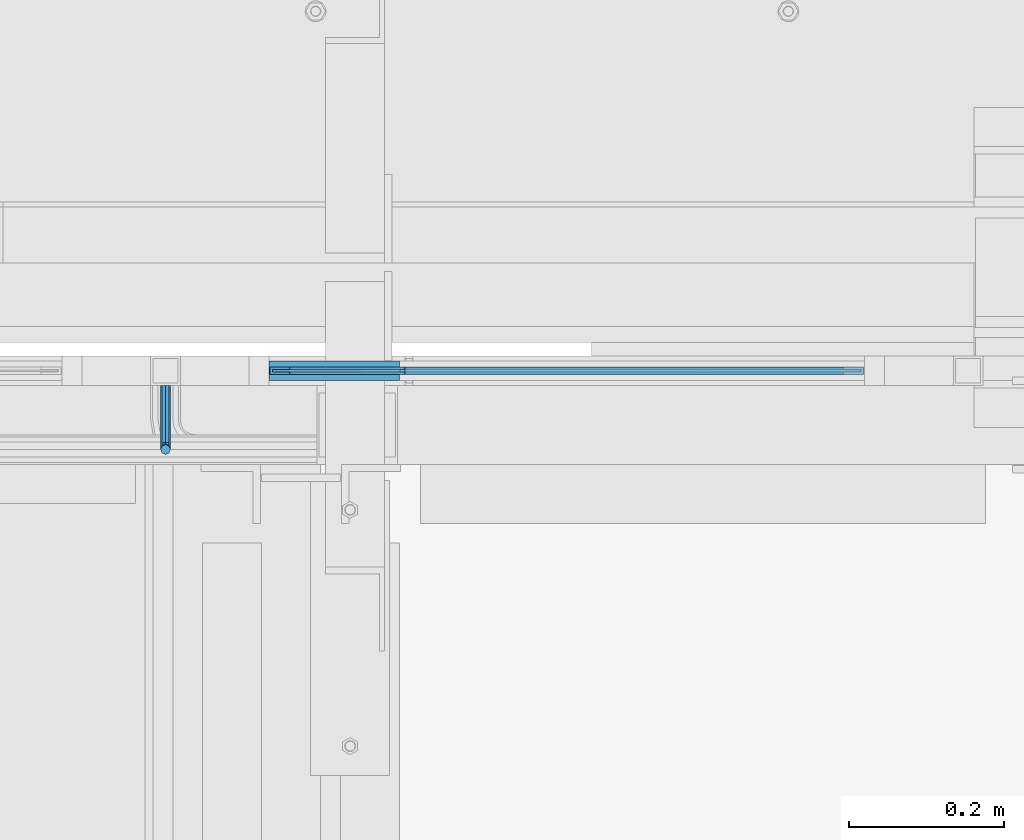
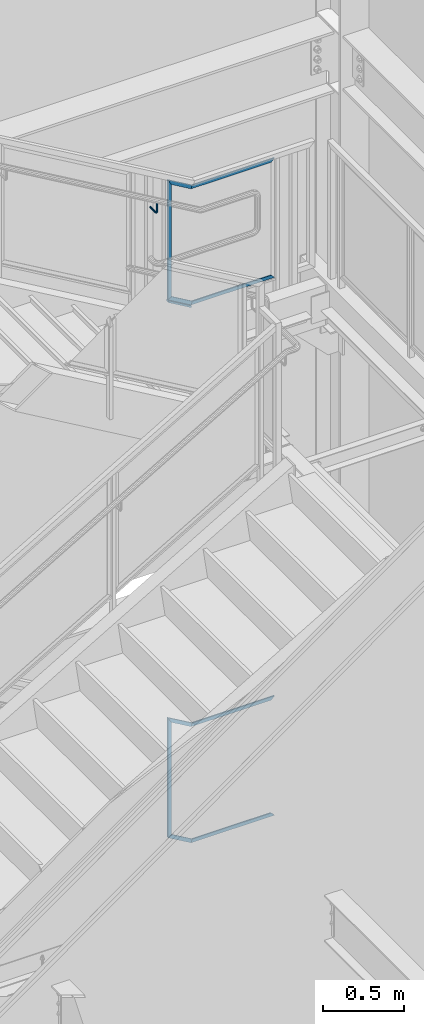
# One storey, part 950 of 1179: 11 beams, 1 member, 2 elements without a shape of their own.
"""IFC2X3 building model written with IfcOpenShell, lengths in millimetres."""

from ifc_helpers import new_model, si_unit, frame, origin_with_axes, place, context, subcontext, project, spatial, faceted_brep, material, type_object, element, aggregate, save


model = new_model("IFC2X3")

# Units and contexts
model_context = context("Model", 3, precision=1e-05, world=origin_with_axes())
body_context = subcontext(model_context, "Body", "Model", "MODEL_VIEW")
ifc_project = project(units=[si_unit("LENGTHUNIT", "METRE", prefix="MILLI"), si_unit("AREAUNIT", "SQUARE_METRE"), si_unit("VOLUMEUNIT", "CUBIC_METRE"), si_unit("MASSUNIT", "GRAM", prefix="KILO"), si_unit("TIMEUNIT", "SECOND"), si_unit("PLANEANGLEUNIT", "RADIAN"), si_unit("SOLIDANGLEUNIT", "STERADIAN"), si_unit("THERMODYNAMICTEMPERATUREUNIT", "DEGREE_CELSIUS"), si_unit("LUMINOUSINTENSITYUNIT", "LUMEN")], contexts=[model_context])

# Site, building, storey
site_placement = place(None, origin_with_axes())
site = spatial("IfcSite", under=ifc_project, at=site_placement, CompositionType="ELEMENT")
building_placement = place(site_placement, origin_with_axes())
building = spatial("IfcBuilding", under=site, at=building_placement, Name="Undefined", CompositionType="ELEMENT")
storey_placement = place(building_placement, origin_with_axes())
storey = spatial("IfcBuildingStorey", under=building, at=storey_placement, Name="Undefined", CompositionType="ELEMENT", Elevation=0.0)

# Assembly, beams
assembly_1_placement = place(storey_placement, origin_with_axes())
assembly_1 = element("IfcElementAssembly", 1, at=assembly_1_placement, inside=storey, Name="GUARDRAIL", AssemblyPlace="NOTDEFINED", PredefinedType="RIGID_FRAME")
ifc_material_1 = material(Name="STEEL/BUY-OUT")
beam_type_1 = type_object("IfcBeamType", PredefinedType="NOTDEFINED")
beam_1_placement = place(assembly_1_placement, frame((23004.4625009229, 41062.2751647691, 7024.57509134663), z_axis=(0.0, 0.0, -1.0), x_axis=(-1.0, 0.0, 0.0)))
beam_1 = element("IfcBeam", 2, at=beam_1_placement, type_object=beam_type_1, material=ifc_material_1, Name="U-EDGE", context=body_context, shape_type="Brep", body=[
    faceted_brep([(0.0, 1.58750000000146, -270.003166662049), (0.0, -1.58750000000146, -270.003166662049), (0.0, -1.58750000000146, 579.92999369853), (0.0, 1.58750000000146, 579.92999369853), (22.225000034312, 1.58750000000146, -308.697692489856), (22.225000034312, 1.58750000000146, 592.695374273017), (22.225000034312, 4.76249999999709, -308.697692489856), (22.225000034312, 4.76249999999709, 592.695374273017), (6.88160071149468e-08, 4.76249999999709, -270.00316678186), (6.88160071149468e-08, 4.76249999999709, 579.929993738056), (6.88160071149468e-08, 7.9375, -270.00316678186), (6.88160071149468e-08, 7.9375, 579.929993738056), (25.4000000343149, 7.9375, -314.225481885294), (25.4000000343149, 7.9375, 594.519), (25.4000000343149, -1.58750000000146, -314.225481885294), (25.4000000343149, -1.58750000000146, 594.519)], [[[0, 1, 2, 3]], [[4, 0, 3, 5]], [[6, 4, 5, 7]], [[8, 6, 7, 9]], [[10, 8, 9, 11]], [[12, 10, 11, 13]], [[14, 12, 13, 15]], [[11, 9, 7, 5, 3, 2, 15, 13]], [[1, 14, 15, 2]], [[0, 4, 6, 8, 10, 12, 14, 1]]]),
])
beam_2_placement = place(assembly_1_placement, frame((23479.7973020287, 41062.2751647691, 7017.29993523606), z_axis=(0.863778851027978, 0.0, -0.503871111016285), x_axis=(0.503871025088838, 0.0, 0.863778901152328)))
beam_2 = element("IfcBeam", 3, at=beam_2_placement, type_object=beam_type_1, material=ifc_material_1, Name="U-EDGE", context=body_context, shape_type="Brep", body=[
    faceted_brep([(-2.06637196242809e-09, 1.58750000000146, -386.433666311852), (25.4000002048124, 1.58750000000146, -393.300527584164), (25.4000001784334, 1.58750000000146, -594.51900000087), (-2.9431248549372e-09, 1.58750000000146, -550.296685272686), (-2.06637196242809e-09, -1.58750000000146, -386.433666311852), (-2.9431248549372e-09, -1.58750000000146, -550.296685272686), (22.2250002049223, -1.58750000000146, -392.44216993215), (22.2250001791581, -1.58750000000146, -588.991210579159), (22.2250002542896, -4.76249993750389, -392.442169945494), (22.2250002532455, -4.76249990620272, -588.991210708155), (5.21009496878833e-07, -4.76249995140824, -386.433666453266), (5.25629729963839e-07, -4.76249993080273, -550.296686192945), (5.21009496878833e-07, -7.93749995141116, -386.433666453266), (5.25629729963839e-07, -7.93749993080564, -550.296686192945), (25.4000002542853, -7.93749993736856, -393.300527597541), (25.4000002532193, -7.93749990531796, -594.51900000187)], [[[0, 1, 2, 3]], [[4, 0, 3, 5]], [[6, 4, 5, 7]], [[8, 6, 7, 9]], [[10, 8, 9, 11]], [[12, 10, 11, 13]], [[14, 12, 13, 15]], [[11, 9, 7, 5, 3, 2, 15, 13]], [[1, 14, 15, 2]], [[0, 4, 6, 8, 10, 12, 14, 1]]]),
])
beam_3_placement = place(assembly_1_placement, frame((22645.5025845213, 41062.2751647691, 6654.0383825364), z_axis=(0.863778851027978, 0.0, -0.503871111016285), x_axis=(-0.503871111016286, 0.0, -0.863778851027978)))
beam_3 = element("IfcBeam", 4, at=beam_3_placement, type_object=beam_type_1, material=ifc_material_1, Name="U-EDGE", context=body_context, shape_type="Brep", body=[
    faceted_brep([(-2.69210431724787e-09, 1.58750000000146, 415.569211323445), (-2.69210431724787e-09, -1.58750000000146, 415.569211323445), (-3.80168785341084e-09, -1.58750000000146, 587.652134403934), (-3.80168785341084e-09, 1.58750000000146, 587.652134403934), (22.2250000252243, 1.58750000000146, 402.803830595183), (22.225000019891, 1.58750000000146, 593.660643821861), (22.2250000338972, 4.76249998905405, 402.803830590206), (22.2250000326712, 4.76249998386629, 593.660643825317), (7.23375706002116e-08, 4.76249999106949, 415.569211280346), (7.22138793207705e-08, 4.7624999873733, 587.652134424485), (7.23375706002116e-08, 7.9374999910724, 415.56921128035), (7.22138793207705e-08, 7.93749998736894, 587.652134424485), (25.4000000339074, 7.93749998910062, 400.980204774167), (25.4000000343149, 7.9375, 594.519), (25.4000000252745, -1.58750000000146, 400.980204779122), (25.4000000343149, -1.58750000000146, 594.519)], [[[0, 1, 2, 3]], [[4, 0, 3, 5]], [[6, 4, 5, 7]], [[8, 6, 7, 9]], [[10, 8, 9, 11]], [[12, 10, 11, 13]], [[14, 12, 13, 15]], [[11, 9, 7, 5, 3, 2, 15, 13]], [[1, 14, 15, 2]], [[0, 4, 6, 8, 10, 12, 14, 1]]]),
])
beam_4_placement = place(assembly_1_placement, frame((23149.7190009069, 41062.2751647691, 6357.93700004089), z_axis=(1.0, 0.0, 0.0), x_axis=(0.0, 0.0, -1.0)))
beam_4 = element("IfcBeam", 5, at=beam_4_placement, type_object=beam_type_1, material=ifc_material_1, Name="U-EDGE", context=body_context, shape_type="Brep", body=[
    faceted_brep([(0.0, 1.58750000000146, 3.38468742659097), (0.0, -1.58750000000146, 3.38468742659097), (0.0, -1.58750000000146, 569.118999689985), (0.0, 1.58750000000146, 569.118999689985), (22.2250000408876, 1.58750000000146, -2.62382239321596), (22.2250000408876, 1.58750000000146, 591.343999668014), (22.2250000408876, 4.76249999999709, -2.62382239321596), (22.2250000408876, 4.76249999999709, 591.343999668014), (8.17417458165437e-08, 4.76249999999709, 3.38468740449025), (8.17417458165437e-08, 4.76249999999709, 569.118999771727), (8.17417458165437e-08, 7.9375, 3.38468740449025), (8.17417458165437e-08, 7.9375, 569.118999771727), (25.4000000408869, 7.9375, -3.4821809373243), (25.4000000343149, 7.9375, 594.519), (25.4000000408869, -1.58750000000146, -3.4821809373243), (25.4000000343149, -1.58750000000146, 594.519)], [[[0, 1, 2, 3]], [[4, 0, 3, 5]], [[6, 4, 5, 7]], [[8, 6, 7, 9]], [[10, 8, 9, 11]], [[12, 10, 11, 13]], [[14, 12, 13, 15]], [[11, 9, 7, 5, 3, 2, 15, 13]], [[1, 14, 15, 2]], [[0, 4, 6, 8, 10, 12, 14, 1]]]),
])
beam_5_placement = place(assembly_1_placement, frame((23149.7190009037, 41062.2751647691, 7212.01200005103), z_axis=(1.0, 0.0, 0.0), x_axis=(0.0, 0.0, 1.0)))
beam_5 = element("IfcBeam", 6, at=beam_5_placement, type_object=beam_type_1, material=ifc_material_1, Name="U-EDGE", context=body_context, shape_type="Brep", body=[
    faceted_brep([(-1.02174453786574e-07, -4.76249999999709, -3.71549147667611), (-1.02174453786574e-07, -7.9375, -3.71549147667611), (-1.02174453786574e-07, -7.9375, 569.11899985779), (-1.02174453786574e-07, -4.76249999999709, 569.11899985779), (22.2249999489695, -4.76249999999709, 2.29301266474431), (22.2249999489695, -4.76249999999709, 591.343999971796), (22.2249999489695, -1.58750000000146, 2.29301266474431), (22.2249999489695, -1.58750000000146, 591.343999971796), (0.0, -1.58750000000146, -3.71549144905293), (0.0, -1.58750000000146, 569.118999689985), (0.0, 1.58750000000146, -3.71549144905293), (0.0, 1.58750000000146, 569.118999689985), (25.3999999489688, 1.58750000000146, 3.15137039725596), (25.3999999489688, 1.58750000000146, 594.519), (25.3999999489688, -7.9375, 3.15137039725596), (25.3999999489688, -7.9375, 594.519)], [[[0, 1, 2, 3]], [[4, 0, 3, 5]], [[6, 4, 5, 7]], [[8, 6, 7, 9]], [[10, 8, 9, 11]], [[12, 10, 11, 13]], [[14, 12, 13, 15]], [[11, 9, 7, 5, 3, 2, 15, 13]], [[1, 14, 15, 2]], [[0, 4, 6, 8, 10, 12, 14, 1]]]),
])

assembly_2_placement = place(storey_placement, origin_with_axes())
assembly_2 = element("IfcElementAssembly", 7, at=assembly_2_placement, inside=storey, Name="GUARDRAIL", AssemblyPlace="NOTDEFINED", PredefinedType="RIGID_FRAME")
beam_6_placement = place(assembly_2_placement, frame((23004.2487243082, 41062.2751647691, 2812.82353977758), z_axis=(0.0, 0.0, -1.0), x_axis=(-1.0, 0.0, 0.0)))
beam_6 = element("IfcBeam", 8, at=beam_6_placement, type_object=beam_type_1, material=ifc_material_1, Name="U-EDGE", context=body_context, shape_type="Brep", body=[
    faceted_brep([(2.91038304567337e-11, 7.9375, 442.556144312037), (25.400000000016, 7.9375, 457.2), (25.400000000016, 7.9375, -451.842250711938), (2.91038304567337e-11, 7.9375, -407.785547856803), (2.91038304567337e-11, 4.76249999999709, 442.556144312037), (2.91038304567337e-11, 4.76249999999709, -407.785547856803), (22.2250000000131, 4.76249999999709, 455.369518039193), (22.2250000000131, 4.76249999999709, -446.335162855043), (22.2250000000131, 1.58750000000146, 455.369518039193), (22.2250000000131, 1.58750000000146, -446.335162855043), (0.0, 1.58750000000146, 442.55614431202), (0.0, 1.58750000000146, -407.785547856753), (0.0, -1.58750000000146, 442.55614431202), (0.0, -1.58750000000146, -407.785547856753), (25.400000000016, -1.58750000000146, 457.2), (25.400000000016, -1.58750000000146, -451.842250711938)], [[[0, 1, 2, 3]], [[4, 0, 3, 5]], [[6, 4, 5, 7]], [[8, 6, 7, 9]], [[10, 8, 9, 11]], [[12, 10, 11, 13]], [[14, 12, 13, 15]], [[11, 9, 7, 5, 3, 2, 15, 13]], [[1, 14, 15, 2]], [[0, 4, 6, 8, 10, 12, 14, 1]]]),
])
beam_7_placement = place(assembly_2_placement, frame((23357.6651990045, 41062.2751647691, 3015.98340288031), z_axis=(0.86540914081268, 0.0, -0.501065882891521), x_axis=(0.501065882891522, 0.0, 0.865409140812679)))
beam_7 = element("IfcBeam", 9, at=beam_7_placement, type_object=beam_type_1, material=ifc_material_1, Name="U-EDGE", context=body_context, shape_type="Brep", body=[
    faceted_brep([(9.74741851678118e-08, -4.76249999670108, -408.380797089678), (9.74741851678118e-08, -7.93749999670399, -408.380797089678), (9.7581505542621e-08, -7.93749999802822, -244.487005042745), (9.7581505542621e-08, -4.76249999802531, -244.487005042745), (22.225000047627, -4.76249999544962, -446.930412123944), (22.2250000481799, -4.7624999974505, -250.45684240964), (22.2250000440508, -1.58750000000146, -446.930412117745), (22.2250000461772, -1.58750000000146, -250.456842409101), (-1.1423253454268e-09, -1.58750000000146, -408.380796918627), (-6.82121026329696e-10, -1.58750000000146, -244.487005016344), (-1.1423253454268e-09, 1.58750000000146, -408.380796918627), (-6.82121026329696e-10, 1.58750000000146, -244.487005016344), (25.4000000439901, 1.58750000000146, -452.437500000357), (25.4000000461656, 1.58750000000146, -251.309676320547), (25.4000000476099, -7.93749999539432, -452.437500000422), (25.4000000481774, -7.93749999743886, -251.309676321089)], [[[0, 1, 2, 3]], [[4, 0, 3, 5]], [[6, 4, 5, 7]], [[8, 6, 7, 9]], [[10, 8, 9, 11]], [[12, 10, 11, 13]], [[14, 12, 13, 15]], [[11, 9, 7, 5, 3, 2, 15, 13]], [[1, 14, 15, 2]], [[0, 4, 6, 8, 10, 12, 14, 1]]]),
])
beam_8_placement = place(assembly_2_placement, frame((23291.8000029085, 41062.2751647691, 3138.48749992319), z_axis=(1.0, 0.0, 0.0), x_axis=(0.0, 0.0, 1.0)))
beam_8 = element("IfcBeam", 10, at=beam_8_placement, type_object=beam_type_1, material=ifc_material_1, Name="U-EDGE", context=body_context, shape_type="Brep", body=[
    faceted_brep([(1.29148247651756e-10, -4.76249999999709, -145.716092850209), (22.2250000000645, -4.76249999999709, -139.746255438797), (22.2250000000645, -1.58750000000146, -139.746255438797), (0.0, -1.58750000000146, -145.716092850242), (0.0, 1.58750000000146, -145.716092850242), (25.4000000000647, 1.58750000000146, -138.893421522876), (25.4000000000647, -7.9375, -138.893421522876), (1.29148247651756e-10, -7.9375, -145.716092850209), (25.4000000000647, -7.9375, 452.4375), (1.29148247651756e-10, -7.9375, 427.037500076181), (1.29148247651756e-10, -4.76249999999709, 427.037500076181), (22.2250000000645, -4.76249999999709, 449.262500076118), (22.2250000000645, -1.58750000000146, 449.262500076118), (0.0, -1.58750000000146, 427.037500076054), (0.0, 1.58750000000146, 427.037500076054), (25.4000000000647, 1.58750000000146, 452.4375)], [[[0, 1, 2, 3, 4, 5, 6, 7]], [[7, 6, 8, 9]], [[0, 7, 9, 10]], [[1, 0, 10, 11]], [[2, 1, 11, 12]], [[3, 2, 12, 13]], [[4, 3, 13, 14]], [[5, 4, 14, 15]], [[6, 5, 15, 8]], [[14, 13, 12, 11, 10, 9, 8, 15]]]),
])
beam_9_placement = place(assembly_2_placement, frame((22643.9340672807, 41062.2751647691, 2578.88707990434), z_axis=(0.86540914081268, 0.0, -0.501065882891521), x_axis=(-0.501065882891527, 0.0, -0.865409140812677)))
beam_9 = element("IfcBeam", 11, at=beam_9_placement, type_object=beam_type_1, material=ifc_material_1, Name="U-EDGE", context=body_context, shape_type="Brep", body=[
    faceted_brep([(2.39240762311965e-07, 7.93749999378633, 587.696328464168), (25.4000000343149, 7.9375, 594.519), (25.4000001184813, 7.93749999461579, 401.707948420833), (2.39342625718564e-07, 7.93749999559805, 416.351804051519), (2.39240762311965e-07, 4.76249999378342, 587.696328464168), (2.39342625718564e-07, 4.76249999559514, 416.351804051519), (22.2250001178327, 4.76249999204447, 593.666165840914), (22.2250001184766, 4.76249999459105, 403.538430383382), (22.2250001115262, 1.58750000000146, 593.666165839222), (22.2250001141911, 1.58750000000146, 403.538430385848), (-2.01180228032172e-09, 1.58750000000146, 587.696328399368), (-1.42608769237995e-09, 1.58750000000146, 416.351804190326), (-2.01180228032172e-09, -1.58750000000146, 587.696328399368), (-1.42608769237995e-09, -1.58750000000146, 416.351804190326), (25.4000000343149, -1.58750000000146, 594.519), (25.4000001142158, -1.58750000000146, 401.707948423293)], [[[0, 1, 2, 3]], [[4, 0, 3, 5]], [[6, 4, 5, 7]], [[8, 6, 7, 9]], [[10, 8, 9, 11]], [[12, 10, 11, 13]], [[14, 12, 13, 15]], [[11, 9, 7, 5, 3, 2, 15, 13]], [[1, 14, 15, 2]], [[0, 4, 6, 8, 10, 12, 14, 1]]]),
])
beam_10_placement = place(assembly_2_placement, frame((23149.7185024644, 41062.2751647691, 2284.41250011933), z_axis=(1.0, 0.0, 0.0), x_axis=(0.0, 0.0, -1.0)))
beam_10 = element("IfcBeam", 12, at=beam_10_placement, type_object=beam_type_1, material=ifc_material_1, Name="U-EDGE", context=body_context, shape_type="Brep", body=[
    faceted_brep([(8.17417458165437e-08, 7.9375, 569.118999771727), (25.4000000343149, 7.9375, 594.519), (25.4000001193604, 7.9375, -4.00933168713891), (2.38696884480305e-07, 7.9375, 2.81333957478637), (8.17417458165437e-08, 4.76249999999709, 569.118999771727), (2.38696884480305e-07, 4.76249999999709, 2.81333957478637), (22.2250000408876, 4.76249999999709, 591.343999668014), (22.2250001193602, 4.76249999999709, -3.15649777539147), (22.2250000408876, 1.58750000000146, 591.343999668014), (22.2250001193602, 1.58750000000146, -3.15649777539147), (0.0, 1.58750000000146, 569.118999689985), (0.0, 1.58750000000146, 2.81333963890211), (0.0, -1.58750000000146, 569.118999689985), (0.0, -1.58750000000146, 2.81333963890211), (25.4000000343149, -1.58750000000146, 594.519), (25.4000001193604, -1.58750000000146, -4.00933168713891)], [[[0, 1, 2, 3]], [[4, 0, 3, 5]], [[6, 4, 5, 7]], [[8, 6, 7, 9]], [[10, 8, 9, 11]], [[12, 10, 11, 13]], [[14, 12, 13, 15]], [[11, 9, 7, 5, 3, 2, 15, 13]], [[1, 14, 15, 2]], [[0, 4, 6, 8, 10, 12, 14, 1]]]),
])
aggregate(assembly_2, [beam_6, beam_7, beam_8, beam_9, beam_10])

# Beam
ifc_material_2 = material(Name="STEEL/A36")
beam_type_2 = type_object("IfcBeamType", PredefinedType="NOTDEFINED")
beam_11_placement = place(assembly_1_placement, frame((22844.1250009055, 41046.3999992326, 7190.79354012369), z_axis=(0.0, 0.0, 1.0), x_axis=(0.0, -1.0, 0.0)))
beam_11 = element("IfcBeam", 13, at=beam_11_placement, type_object=beam_type_2, material=ifc_material_2, Name="BRACKET", context=body_context, shape_type="Brep", body=[
    faceted_brep([(0.0, -4.49012806053361, 4.49012806053452), (0.0, 0.0, 6.34999999999991), (0.0, 4.49012806053361, 4.49012806053452), (0.0, 6.34999999999854, 0.0), (0.0, 4.49012806053361, -4.49012806053452), (0.0, 0.0, -6.34999999999991), (0.0, -4.49012806053361, -4.49012806053452), (0.0, -6.34999999999854, 0.0), (69.849999425729, 0.0, -6.34999999999991), (69.849999425729, -4.49012806053361, -4.49012806053452), (69.849999425729, -6.34999999999854, 0.0), (69.849999425729, -4.49012806053361, 4.49012806053452), (69.849999425729, 0.0, 6.34999999999991), (69.849999425729, 4.49012806053361, 4.49012806053452), (69.849999425729, 6.34999999999854, 0.0), (69.849999425729, 4.49012806053361, -4.49012806053452), (78.445063360632, 4.49012806053361, -2.18708762028064), (79.3749993303718, 0.0, -3.79778396764323), (78.445063360632, -4.49012806053361, -2.18708762028064), (76.1999993303689, -6.34999999999854, 1.70147734638658), (73.9549353000984, -4.49012806053361, 5.59004231305425), (73.024999330366, 0.0, 7.20073866041639), (73.9549353000984, 4.49012806053361, 5.59004231305425), (76.1999993303689, 6.34999999999854, 1.70147734638658), (80.8485218886053, 6.34999999999854, 6.34999990462893), (84.7370868552753, 4.49012806053361, 4.10493587436031), (76.9599569219426, 4.49012806053361, 8.59506393489755), (75.3492605745778, 0.0, 9.52499990463093), (76.9599569219426, -4.49012806053361, 8.59506393489755), (80.8485218886053, -6.34999999999854, 6.34999990462893), (84.7370868552753, -4.49012806053361, 4.10493587436031), (86.3477832026401, 0.0, 3.17499990462693), (87.0401272955278, 4.49012806053361, 12.6999998092651), (88.8999992349927, 0.0, 12.6999998092651), (82.5499992349942, 6.34999999999854, 12.6999998092651), (78.0598711744606, 4.49012806053361, 12.6999998092651), (76.1999992349956, 0.0, 12.6999998092651), (78.0598711744606, -4.49012806053361, 12.6999998092651), (82.5499992349942, -6.34999999999854, 12.6999998092651), (87.0401272955278, -4.49012806053361, 12.6999998092651), (88.8999992349927, 0.0, 76.2000000000003), (87.0401272908275, -4.49012806053361, 78.7997529672102), (82.5499992302939, -6.34999999999854, 79.8766059046975), (78.0598711697603, -4.49012806053361, 78.7997529672102), (76.1999992349956, 0.0, 76.2000000000003), (78.0598711697603, 4.49012806053361, 73.6002470344774), (82.5499992302939, 6.34999999999854, 72.5233940969902), (87.0401272908275, 4.49012806053361, 73.6002470344774)], [[[0, 1, 2, 3, 4, 5, 6, 7]], [[6, 5, 8, 9]], [[7, 6, 9, 10]], [[0, 7, 10, 11]], [[1, 0, 11, 12]], [[2, 1, 12, 13]], [[3, 2, 13, 14]], [[4, 3, 14, 15]], [[5, 4, 15, 8]], [[8, 15, 16, 17]], [[9, 8, 17, 18]], [[10, 9, 18, 19]], [[11, 10, 19, 20]], [[12, 11, 20, 21]], [[13, 12, 21, 22]], [[14, 13, 22, 23]], [[15, 14, 23, 16]], [[23, 24, 25, 16]], [[22, 26, 24, 23]], [[21, 27, 26, 22]], [[20, 28, 27, 21]], [[19, 29, 28, 20]], [[18, 30, 29, 19]], [[17, 31, 30, 18]], [[16, 25, 31, 17]], [[25, 32, 33, 31]], [[24, 34, 32, 25]], [[26, 35, 34, 24]], [[27, 36, 35, 26]], [[28, 37, 36, 27]], [[29, 38, 37, 28]], [[30, 39, 38, 29]], [[31, 33, 39, 30]], [[39, 33, 40, 41]], [[38, 39, 41, 42]], [[37, 38, 42, 43]], [[36, 37, 43, 44]], [[35, 36, 44, 45]], [[34, 35, 45, 46]], [[32, 34, 46, 47]], [[33, 32, 47, 40]], [[46, 45, 44, 43, 42, 41, 40, 47]]]),
])

# Member
member_type = type_object("IfcMemberType", PredefinedType="NOTDEFINED")
member_placement = place(assembly_1_placement, frame((22964.7750009048, 41065.4499992401, 6429.20119366884), z_axis=(0.0, -1.0, 0.0), x_axis=(0.863778851027978, 0.0, -0.503871111016285)))
member = element("IfcMember", 14, at=member_placement, type_object=member_type, material=ifc_material_2, Name="BOTTOM_RAIL", context=body_context, shape_type="Brep", body=[
    faceted_brep([(10.9986698874163, 6.34999999999854, -12.6999999999971), (10.9986698874163, 6.34999999999854, 12.6999999999971), (205.878457514689, 6.35000000003492, 12.6999999999971), (205.878457514689, 6.35000000003492, -12.6999999999971), (18.4070032121654, -6.34999999999127, 12.6999999999971), (209.311891609657, -6.34999999996944, 12.6999999999971), (18.4070032121654, -6.34999999999127, -12.6999999999971), (209.311891609657, -6.34999999996944, -12.6999999999971)], [[[0, 1, 2, 3]], [[1, 4, 5, 2]], [[4, 6, 7, 5]], [[6, 0, 3, 7]], [[5, 7, 3, 2]], [[6, 4, 1, 0]]]),
])

aggregate(assembly_1, [beam_11, beam_1, beam_2, beam_3, beam_4, beam_5, member])

save(model, "model.ifc")
